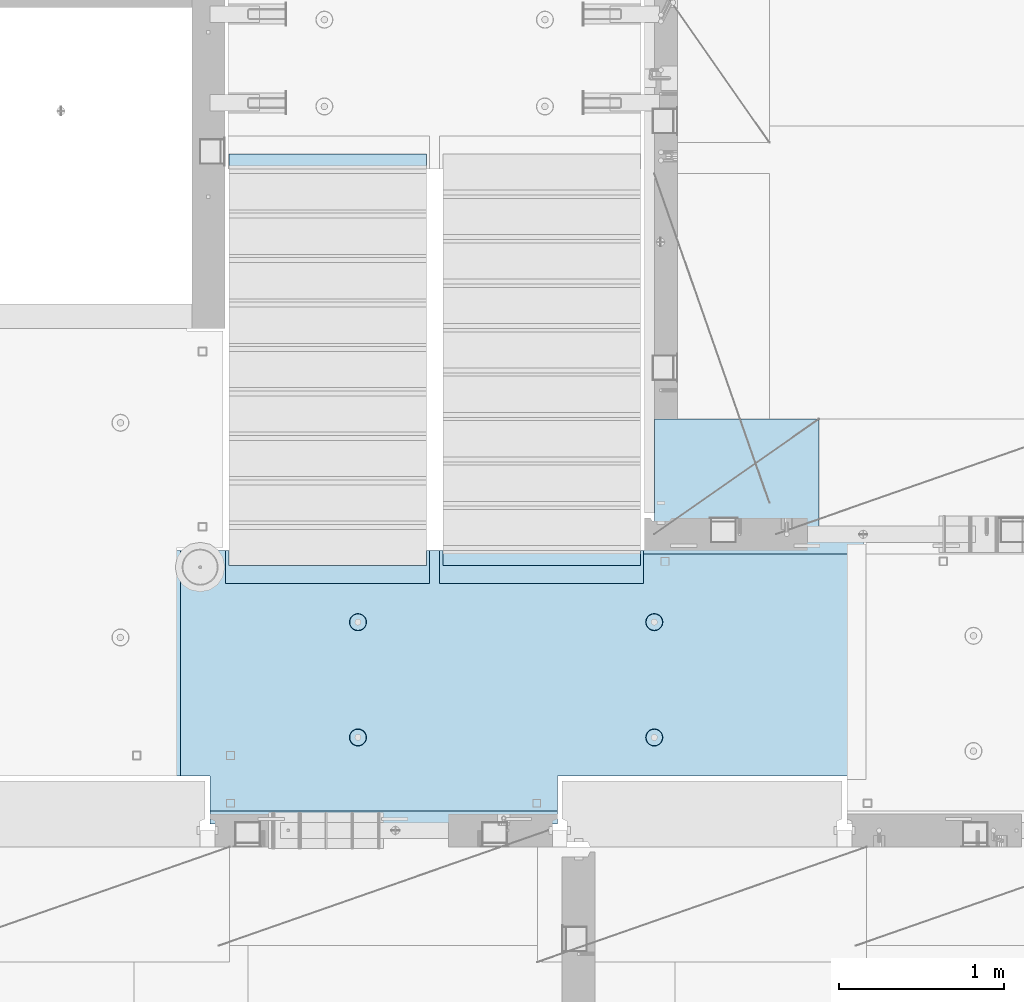
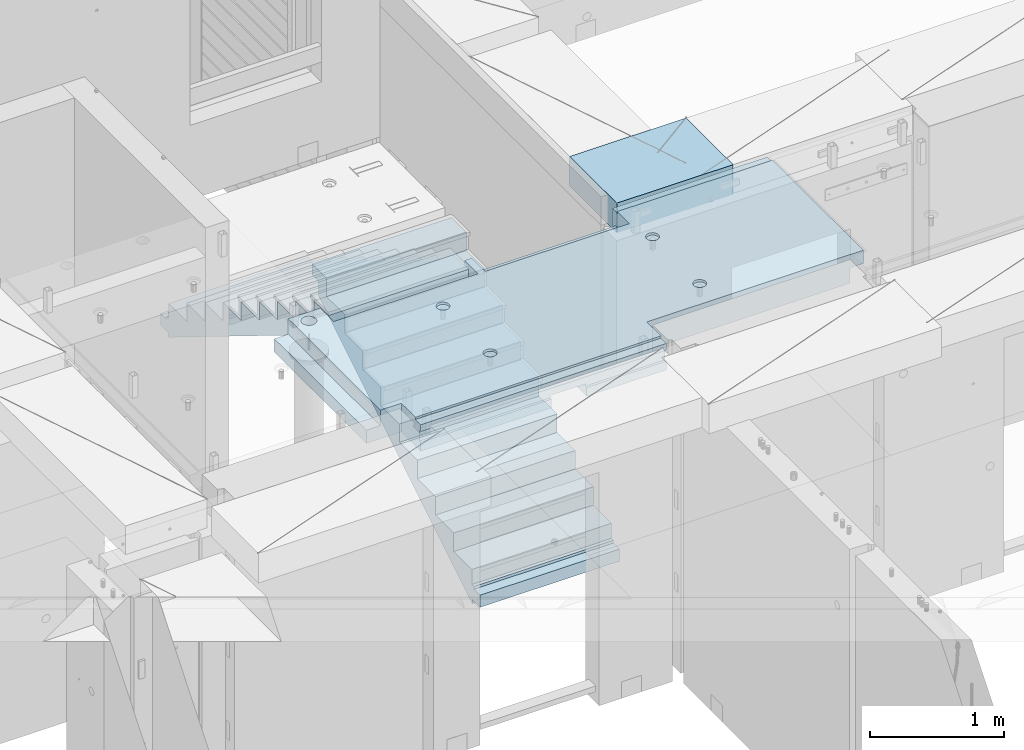
# One storey, part 207 of 349: 3 plates, 1 slab, 4 elements without a shape of their own.
"""IFC2X3 building model written with IfcOpenShell, lengths in millimetres."""

from ifc_helpers import new_model, si_unit, frame, origin_with_axes, place, context, subcontext, project, spatial, faceted_brep, material, type_object, element, aggregate, save


model = new_model("IFC2X3")

# Units and contexts
model_context = context("Model", 3, precision=1e-05, world=origin_with_axes())
body_context = subcontext(model_context, "Body", "Model", "MODEL_VIEW")
ifc_project = project(units=[si_unit("LENGTHUNIT", "METRE", prefix="MILLI"), si_unit("AREAUNIT", "SQUARE_METRE"), si_unit("VOLUMEUNIT", "CUBIC_METRE"), si_unit("MASSUNIT", "GRAM", prefix="KILO"), si_unit("TIMEUNIT", "SECOND"), si_unit("PLANEANGLEUNIT", "RADIAN"), si_unit("SOLIDANGLEUNIT", "STERADIAN"), si_unit("THERMODYNAMICTEMPERATUREUNIT", "DEGREE_CELSIUS"), si_unit("LUMINOUSINTENSITYUNIT", "LUMEN")], contexts=[model_context])

# Site, building, storey
site_placement = place(None, origin_with_axes())
site = spatial("IfcSite", under=ifc_project, at=site_placement, CompositionType="ELEMENT")
building_placement = place(site_placement, origin_with_axes())
building = spatial("IfcBuilding", under=site, at=building_placement, CompositionType="ELEMENT")
storey_placement = place(building_placement, origin_with_axes())
storey = spatial("IfcBuildingStorey", under=building, at=storey_placement, Name="4", CompositionType="ELEMENT", Elevation=0.0)

# Assembly, slab
assembly_1_placement = place(storey_placement, origin_with_axes())
assembly_1 = element("IfcElementAssembly", 1, at=assembly_1_placement, inside=storey, AssemblyPlace="NOTDEFINED", PredefinedType="REINFORCEMENT_UNIT")
ifc_material_1 = material(Name="CONCRETE/C25/30")
slab_type = type_object("IfcSlabType", PredefinedType="NOTDEFINED")
slab_placement = place(assembly_1_placement, frame((23540.0159390845, 15510.0026483125, 93620.0), z_axis=(-0.999999999997437, -2.26400000064461e-06, 0.0), x_axis=(-2.2639999995273e-06, 0.999999999997437, 0.0)))
slab = element("IfcSlab", 2, at=slab_placement, type_object=slab_type, material=ifc_material_1, PredefinedType="FLOOR", context=body_context, shape_type="Brep", body=[
    faceted_brep([(-269.991394356101, 30.0, 2845.00213671412), (-79.9935682977648, 30.0, 2845.00213671301), (-79.9942474988402, 30.0, 2545.001661275), (-269.991475956112, 30.0, 2545.00209142873), (-79.9935682977648, 130.0, 2845.00213671301), (-269.991394356102, 50.0011356208415, 2845.00213671412), (-289.993566176285, 50.0011356208415, 2845.00213671423), (-289.993566176285, 130.0, 2845.00213671423), (-79.9942474988402, 130.0, 2545.001661275), (-289.994243058944, 130.0, 2545.00213671499), (-289.994243058944, 50.0011356208415, 2545.00213671499), (-269.991475956114, 50.0011356208415, 2545.00209142873), (250.667816023648, -110.0, 1223.00869116667), (264.606228919523, -110.0, 1230.11066726268), (275.667816023648, -110.0, 1241.1722543668), (282.76979211966, -110.0, 1255.11066726268), (285.216966304903, -110.0, 1270.56151698143), (282.769792119658, -110.0, 1286.01236670018), (275.667816023648, -110.0, 1299.95077959605), (264.606228919525, -110.0, 1311.01236670018), (250.667816023648, -110.0, 1318.11434279619), (235.216966304901, -110.0, 1320.56151698143), (219.766116586154, -110.0, 1318.11434279619), (205.827703690276, -110.0, 1311.01236670018), (194.766116586154, -110.0, 1299.95077959605), (187.664140490142, -110.0, 1286.01236670018), (185.216966304899, -110.0, 1270.56151698143), (187.664140490144, -110.0, 1255.11066726268), (194.766116586154, -110.0, 1241.1722543668), (205.827703690276, -110.0, 1230.11066726268), (219.766116586154, -110.0, 1223.00869116667), (235.216966304901, -110.0, 1220.56151698143), (251.370127374501, -130.0, 1220.84719908418), (235.216966304901, -130.0, 1218.2887897087), (265.942104492917, -130.0, 1228.27199227546), (277.506491010863, -130.0, 1239.83637879341), (284.931284202146, -130.0, 1254.40835591183), (287.489693577627, -130.0, 1270.56151698143), (284.931284202146, -130.0, 1286.71467805103), (277.506491010861, -130.0, 1301.28665516945), (265.942104492917, -130.0, 1312.85104168739), (251.370127374501, -130.0, 1320.27583487867), (235.216966304901, -130.0, 1322.83424425416), (219.063805235301, -130.0, 1320.27583487867), (204.491828116883, -130.0, 1312.85104168739), (192.927441598938, -130.0, 1301.28665516945), (185.502648407655, -130.0, 1286.71467805103), (182.944239032175, -130.0, 1270.56151698143), (185.502648407655, -130.0, 1254.40835591183), (192.92744159894, -130.0, 1239.83637879341), (204.491828116883, -130.0, 1228.27199227546), (219.063805235301, -130.0, 1220.84719908418), (1370.00988769532, 9.99999999994179, 4270.0029296875), (0.00703133410206647, 9.99999999994179, 4270.00341796875), (0.00594789032584231, 9.99999999994179, 4150.00335886026), (1370.00950450419, 9.99999999994179, 4150.0022190173), (1370.00988769532, 130.0, 4270.0029296875), (0.00703133410206647, 130.0, 4270.00341796875), (-289.995788574217, 50.0011356208415, 1860.01696777343), (-269.99166227209, 50.0011356208415, 1860.01689198933), (-289.995788574217, 130.0, 1860.01696777343), (1410.00403637765, -10.0000000000582, 115.00218916441), (-0.000334584017764428, -10.0000000000582, 115.003668258996), (-0.000334584015945438, 130.0, 115.003668258996), (1430.00436377147, 130.0, 115.002168181909), (1430.00283514406, 50.0011356437899, 115.002168184747), (1410.00403637764, 50.0011356208415, 115.002189163421), (1430.00659179688, 130.0, 1330.01220703125), (1370.00036621094, 130.0, 1330.01281738281), (1370.00036621094, -110.000000000073, 1330.01281738281), (1430.00659179688, -110.000000000073, 1330.01220703125), (1430.00656714066, -110.000000000073, 1.33804860524833e-08), (1350.00656713971, -110.000000000073, -1.09139364212751e-10), (1350.00656713971, -130.0, -9.31322574615479e-10), (0.0, -130.0, -3.63797880709171e-12), (0.0, -10.0, 0.0), (1410.00416932017, -10.0000000000582, 1.69893610291183e-09), (1410.00416932017, -49.9988643791585, 5.89352566748858e-10), (1430.00416932019, -49.9988643791585, 2.83398549072444e-09), (1430.00277003324, 50.0011356208415, 1270.01537795496), (1430.00277003324, -49.9988643791585, 1270.01537795496), (1410.00277003325, 50.0011356208415, 1270.01535591496), (1410.00277003325, -49.9988643791585, 1270.01535591496), (-0.00148380931932479, -130.0, 510.016937255856), (-0.00148380931932479, 130.0, 510.016937255856), (0.00156440050341189, -130.0, 1860.01586914062), (0.00156440050341189, 130.0, 1860.01586914062), (-209.991713751984, -130.000000000058, 1860.01666468411), (-209.996345203012, -130.0, 3970.01713194715), (-209.996345203012, -110.000000000058, 3970.01713194715), (-209.991713751984, -110.000000000058, 1860.01666468411), (-289.991027832028, -110.000000000058, 3970.01733398437), (-289.995788574217, -110.000000000058, 1860.01696777343), (-289.991027832028, -49.9988643791585, 3970.01733398437), (-289.995788574217, -49.9988643791585, 1860.01696777343), (-269.99166227209, -49.9988643791585, 1860.01689198933), (-289.991027832028, 50.0011356208415, 3970.01733398437), (-289.991027832028, 130.0, 3970.01733398437), (-269.991088351981, 50.0011356208415, 3970.01728347186), (-269.991088351981, -49.9988643791585, 3970.01728347186), (0.00432284502676339, -130.0, 3970.0166015625), (0.00432284502676339, 130.0, 3970.0166015625), (0.00594789032584231, -130.0, 4150.00335886026), (1370.00950450419, -130.000000000058, 4150.0022190173), (1370.00860847198, 9.99639270307671, 3875.01157736929), (1170.00318277859, 9.99639270307671, 3875.01203018158), (1170.00037541444, 9.99639270307671, 2635.01019913007), (1370.00459258838, 9.99639270307671, 2635.00974632052), (1370.00860847197, -130.000000000058, 3875.01157736929), (1170.00318277859, -130.000000000029, 3875.01203018158), (1170.00037541444, -130.000000000029, 2635.01019913007), (1370.00459258838, -130.000000000029, 2635.00974632052), (1370.00439827764, -130.000000000029, 2575.01157737549), (1170.00023957859, -130.000000000029, 2575.01203018491), (1170.00023957859, 9.99639270307671, 2575.01203018491), (1370.00439827764, 9.99639270307671, 2575.01157737549), (1169.99743221444, -130.000000000029, 1335.0101991334), (1169.99743221444, 9.99639270307671, 1335.0101991334), (1370.00038239405, 9.99639270307671, 1335.00974632672), (1370.00038239405, -110.000000000073, 1335.00974632672), (1350.00004294686, -110.000000000073, 1335.00979160748), (1350.00004294686, -130.000000000073, 1335.00979160748), (920.332855772751, -110.0, 1318.11282667454), (906.394410719273, -110.0, 1311.01091369173), (895.332773528397, -110.0, 1299.94937667459), (888.230734319324, -110.0, 1286.01099593661), (885.78349017266, -110.0, 1270.56015729882), (888.230594396427, -110.0, 1255.10929649942), (895.332507379233, -110.0, 1241.17085144594), (906.394044396377, -110.0, 1230.10921425507), (920.332425134358, -110.0, 1223.00717504599), (935.783263772144, -110.0, 1220.55993089933), (951.234124571543, -110.0, 1223.0070351231), (965.172569625021, -110.0, 1230.10894810591), (976.234206815898, -110.0, 1241.17048512305), (983.33624602497, -110.0, 1255.10886586103), (985.783490171634, -110.0, 1270.55970449882), (983.336385947867, -110.0, 1286.01056529821), (976.234472965061, -110.0, 1299.94901035169), (965.172935947918, -110.0, 1311.01064754257), (951.234555209936, -110.0, 1318.11268675164), (935.783716572147, -110.0, 1320.5599308983), (951.936426135147, -130.0, 1220.84553986057), (935.783253481237, -130.0, 1218.28720362663), (966.508436872882, -130.0, 1228.27026706986), (978.072875754253, -130.0, 1239.83460122415), (985.497734927369, -130.0, 1254.40654472295), (988.05621744434, -130.0, 1270.55969420791), (985.497881210395, -130.0, 1286.71286686182), (978.073154001104, -130.0, 1301.28487759955), (966.508819846818, -130.0, 1312.84931648092), (951.936876348012, -130.0, 1320.27417565404), (935.783726863054, -130.0, 1322.83265817101), (919.630554209147, -130.0, 1320.27432193707), (905.058543471412, -130.0, 1312.84959472777), (893.494104590041, -130.0, 1301.28526057349), (886.069245416922, -130.0, 1286.71331707469), (883.510762899954, -130.0, 1270.56016758973), (886.069099133892, -130.0, 1254.40699493582), (893.49382634319, -130.0, 1239.83498419809), (905.058160497476, -130.0, 1228.27054531671), (919.630103996282, -130.0, 1220.84568614359), (920.336931380272, -110.0, 3118.29282666992), (906.398486326791, -110.0, 3111.19091368712), (895.336849135918, -110.0, 3100.12937666997), (888.234809926846, -110.0, 3086.19099593199), (885.787565780181, -110.0, 3070.7401572942), (888.234670003949, -110.0, 3055.28929649481), (895.336582986754, -110.0, 3041.35085144133), (906.398120003898, -110.0, 3030.28921425045), (920.33650074188, -110.0, 3023.18717504138), (935.787339379665, -110.0, 3020.73993089472), (951.238200179065, -110.0, 3023.18703511849), (965.176645232543, -110.0, 3030.28894810129), (976.238282423419, -110.0, 3041.35048511844), (983.340321632491, -110.0, 3055.28886585642), (985.787565779156, -110.0, 3070.7397044942), (983.340461555388, -110.0, 3086.1905652936), (976.238548572583, -110.0, 3100.12901034708), (965.177011555439, -110.0, 3111.19064753796), (951.238630817454, -110.0, 3118.29268674703), (935.787792179664, -110.0, 3120.73993089369), (951.940501742669, -130.000000000015, 3021.02553985595), (935.787329088758, -130.000000000015, 3018.46720362201), (966.512512480404, -130.000000000015, 3028.45026706525), (978.076951361778, -130.000000000015, 3040.01460121954), (985.50181053489, -130.000000000015, 3054.58654471834), (988.060293051862, -130.000000000015, 3070.73969420329), (985.501956817916, -130.000000000015, 3086.89286685721), (978.077229608625, -130.000000000015, 3101.46487759494), (966.51289545434, -130.000000000015, 3113.02931647631), (951.940951955534, -130.000000000015, 3120.45417564943), (935.787802470575, -130.000000000015, 3123.01265816639), (919.634629816665, -130.000000000015, 3120.45432193246), (905.062619078933, -130.000000000015, 3113.02959472316), (893.498180197559, -130.000000000015, 3101.46526056888), (886.07332102444, -130.000000000015, 3086.89331707007), (883.514838507475, -130.000000000015, 3070.74016758511), (886.073174741414, -130.000000000015, 3054.5869949312), (893.497901950712, -130.000000000015, 3040.01498419347), (905.062236104997, -130.000000000015, 3028.4505453121), (919.634179603803, -130.000000000015, 3021.02568613898), (250.671891631169, -110.0, 3023.18869116206), (264.610304527045, -110.0, 3030.29066725807), (275.671891631167, -110.0, 3041.35225436219), (282.773867727179, -110.0, 3055.29066725806), (285.221041912424, -110.0, 3070.74151697681), (282.773867727179, -110.0, 3086.19236669556), (275.671891631169, -110.0, 3100.13077959144), (264.610304527047, -110.0, 3111.19236669556), (250.671891631169, -110.0, 3118.29434279157), (235.221041912422, -110.0, 3120.74151697681), (219.770192193675, -110.0, 3118.29434279157), (205.831779297798, -110.0, 3111.19236669556), (194.770192193675, -110.0, 3100.13077959144), (187.668216097663, -110.0, 3086.19236669556), (185.22104191242, -110.0, 3070.74151697681), (187.668216097663, -110.0, 3055.29066725806), (194.770192193673, -110.0, 3041.35225436219), (205.831779297798, -110.0, 3030.29066725807), (219.770192193673, -110.0, 3023.18869116206), (235.221041912422, -110.0, 3020.74151697681), (251.374202982022, -130.0, 3021.02719907957), (235.221041912422, -130.0, 3018.46878970409), (265.946180100438, -130.0, 3028.45199227085), (277.510566618384, -130.0, 3040.0163787888), (284.935359809668, -130.0, 3054.58835590722), (287.493769185148, -130.0, 3070.74151697681), (284.935359809668, -130.0, 3086.89467804641), (277.510566618383, -130.0, 3101.46665516483), (265.946180100438, -130.0, 3113.03104168278), (251.374202982022, -130.0, 3120.45583487406), (235.22104191242, -130.0, 3123.01424424954), (219.067880842822, -130.0, 3120.45583487406), (204.495903724404, -130.0, 3113.03104168278), (192.93151720646, -130.0, 3101.46665516483), (185.506724015177, -130.0, 3086.89467804641), (182.948314639694, -130.0, 3070.74151697681), (185.506724015177, -130.0, 3054.58835590722), (192.93151720646, -130.0, 3040.0163787888), (204.495903724404, -130.0, 3028.45199227085), (219.06788084282, -130.0, 3021.02719907957), (1234.74413944682, -130.000000000029, 3981.4733287671), (1221.47026497402, -130.000000000029, 3994.74726334413), (1212.94793152671, -130.000000000029, 4011.47337811379), (1210.0113644813, -130.000000000029, 4030.01440442472), (1212.94801548044, -130.000000000029, 4048.55541743869), (1221.47042466352, -130.000000000029, 4065.28149361904), (1234.74435924055, -130.000000000029, 4078.55536809184), (1251.47047401021, -130.000000000029, 4087.07770153915), (1270.01150032114, -130.000000000029, 4090.01426858456), (1288.55251333511, -130.000000000029, 4087.07761758541), (1305.27858951547, -130.000000000029, 4078.55520840234), (1318.55246398826, -130.000000000029, 4065.28127382531), (1327.07479743557, -130.000000000029, 4048.55515905565), (1330.01136448099, -130.000000000029, 4030.01413274472), (1327.07471348184, -130.000000000029, 4011.47311973075), (1318.55230429877, -130.000000000029, 3994.74704355039), (1305.27836972173, -130.000000000029, 3981.4731690776), (1288.55225495208, -130.000000000029, 3972.95083563029), (1270.01122864114, -130.000000000029, 3970.01426858487), (1251.47021562717, -130.000000000029, 3972.95091958403), (1305.27836972173, 130.0, 3981.4731690776), (1288.55225495208, 130.0, 3972.95083563029), (1318.55230429877, 130.0, 3994.74704355039), (1327.07471348184, 130.0, 4011.47311973075), (1330.01136448099, 130.0, 4030.01413274472), (1327.07479743557, 130.0, 4048.55515905565), (1318.55246398826, 130.0, 4065.28127382531), (1305.27858951547, 130.0, 4078.55520840234), (1288.55251333511, 130.0, 4087.07761758541), (1270.01150032114, 130.0, 4090.01426858456), (1251.47047401021, 130.0, 4087.07770153915), (1234.74435924055, 130.0, 4078.55536809184), (1221.47042466352, 130.0, 4065.28149361904), (1212.94801548044, 130.0, 4048.55541743869), (1210.0113644813, 130.0, 4030.01440442472), (1212.94793152671, 130.0, 4011.47337811379), (1221.47026497402, 130.0, 3994.74726334413), (1234.74413944682, 130.0, 3981.4733287671), (1251.47021562717, 130.0, 3972.95091958403), (1270.01122864114, 130.0, 3970.01426858487)], [[[0, 1, 2, 3]], [[4, 1, 0, 5, 6, 7]], [[8, 2, 1, 4]], [[9, 10, 11, 3, 2, 8]], [[12, 13, 14, 15, 16, 17, 18, 19, 20, 21, 22, 23, 24, 25, 26, 27, 28, 29, 30, 31]], [[32, 12, 31, 33]], [[34, 13, 12, 32]], [[35, 14, 13, 34]], [[36, 15, 14, 35]], [[37, 16, 15, 36]], [[38, 17, 16, 37]], [[39, 18, 17, 38]], [[40, 19, 18, 39]], [[41, 20, 19, 40]], [[42, 21, 20, 41]], [[43, 22, 21, 42]], [[44, 23, 22, 43]], [[45, 24, 23, 44]], [[46, 25, 24, 45]], [[47, 26, 25, 46]], [[48, 27, 26, 47]], [[49, 28, 27, 48]], [[50, 29, 28, 49]], [[51, 30, 29, 50]], [[33, 31, 30, 51]], [[52, 53, 54, 55]], [[56, 57, 53, 52]], [[58, 59, 11, 10]], [[60, 58, 10, 9]], [[61, 62, 63, 64, 65, 66]], [[67, 68, 69, 70]], [[71, 72, 73, 74, 75, 76, 77, 78]], [[79, 65, 64, 67, 70, 71, 78, 80]], [[65, 79, 81, 66]], [[80, 82, 81, 79]], [[78, 77, 82, 80]], [[76, 61, 66, 81, 82, 77]], [[75, 62, 61, 76]], [[74, 83, 84, 63, 62, 75]], [[83, 85, 86, 84]], [[87, 88, 89, 90]], [[90, 89, 91, 92]], [[92, 91, 93, 94]], [[58, 60, 86, 85, 87, 90, 92, 94, 95, 59]], [[96, 97, 7, 6]], [[98, 96, 6, 5]], [[59, 95, 99, 98, 5, 0, 3, 11]], [[94, 93, 99, 95]], [[91, 89, 88, 100, 101, 97, 96, 98, 99, 93]], [[53, 57, 101, 100, 102, 54]], [[103, 55, 54, 102]], [[104, 105, 106, 107]], [[108, 109, 105, 104]], [[110, 106, 105, 109]], [[111, 107, 106, 110]], [[112, 113, 114, 115]], [[116, 117, 114, 113]], [[115, 114, 117, 118]], [[69, 68, 56, 52, 55, 103, 108, 104, 107, 111, 112, 115, 118, 119]], [[72, 71, 70, 69, 119, 120]], [[73, 72, 120, 121]], [[119, 118, 117, 116, 121, 120]], [[122, 123, 124, 125, 126, 127, 128, 129, 130, 131, 132, 133, 134, 135, 136, 137, 138, 139, 140, 141]], [[142, 132, 131, 143]], [[144, 133, 132, 142]], [[145, 134, 133, 144]], [[146, 135, 134, 145]], [[147, 136, 135, 146]], [[148, 137, 136, 147]], [[149, 138, 137, 148]], [[150, 139, 138, 149]], [[151, 140, 139, 150]], [[152, 141, 140, 151]], [[153, 122, 141, 152]], [[154, 123, 122, 153]], [[155, 124, 123, 154]], [[156, 125, 124, 155]], [[157, 126, 125, 156]], [[158, 127, 126, 157]], [[159, 128, 127, 158]], [[160, 129, 128, 159]], [[161, 130, 129, 160]], [[143, 131, 130, 161]], [[162, 163, 164, 165, 166, 167, 168, 169, 170, 171, 172, 173, 174, 175, 176, 177, 178, 179, 180, 181]], [[182, 172, 171, 183]], [[184, 173, 172, 182]], [[185, 174, 173, 184]], [[186, 175, 174, 185]], [[187, 176, 175, 186]], [[188, 177, 176, 187]], [[189, 178, 177, 188]], [[190, 179, 178, 189]], [[191, 180, 179, 190]], [[192, 181, 180, 191]], [[193, 162, 181, 192]], [[194, 163, 162, 193]], [[195, 164, 163, 194]], [[196, 165, 164, 195]], [[197, 166, 165, 196]], [[198, 167, 166, 197]], [[199, 168, 167, 198]], [[200, 169, 168, 199]], [[201, 170, 169, 200]], [[183, 171, 170, 201]], [[202, 203, 204, 205, 206, 207, 208, 209, 210, 211, 212, 213, 214, 215, 216, 217, 218, 219, 220, 221]], [[222, 202, 221, 223]], [[224, 203, 202, 222]], [[225, 204, 203, 224]], [[226, 205, 204, 225]], [[227, 206, 205, 226]], [[228, 207, 206, 227]], [[229, 208, 207, 228]], [[230, 209, 208, 229]], [[231, 210, 209, 230]], [[232, 211, 210, 231]], [[233, 212, 211, 232]], [[234, 213, 212, 233]], [[235, 214, 213, 234]], [[236, 215, 214, 235]], [[237, 216, 215, 236]], [[238, 217, 216, 237]], [[239, 218, 217, 238]], [[240, 219, 218, 239]], [[241, 220, 219, 240]], [[223, 221, 220, 241]], [[113, 112, 111, 110, 109, 108, 103, 102, 100, 88, 87, 85, 83, 74, 73, 121, 116], [240, 239, 238, 237, 236, 235, 234, 233, 232, 231, 230, 229, 228, 227, 226, 225, 224, 222, 223, 241], [200, 199, 198, 197, 196, 195, 194, 193, 192, 191, 190, 189, 188, 187, 186, 185, 184, 182, 183, 201], [160, 159, 158, 157, 156, 155, 154, 153, 152, 151, 150, 149, 148, 147, 146, 145, 144, 142, 143, 161], [50, 49, 48, 47, 46, 45, 44, 43, 42, 41, 40, 39, 38, 37, 36, 35, 34, 32, 33, 51], [242, 243, 244, 245, 246, 247, 248, 249, 250, 251, 252, 253, 254, 255, 256, 257, 258, 259, 260, 261]], [[258, 262, 263, 259]], [[257, 264, 262, 258]], [[256, 265, 264, 257]], [[255, 266, 265, 256]], [[254, 267, 266, 255]], [[253, 268, 267, 254]], [[252, 269, 268, 253]], [[251, 270, 269, 252]], [[250, 271, 270, 251]], [[249, 272, 271, 250]], [[248, 273, 272, 249]], [[247, 274, 273, 248]], [[246, 275, 274, 247]], [[245, 276, 275, 246]], [[244, 277, 276, 245]], [[243, 278, 277, 244]], [[242, 279, 278, 243]], [[261, 280, 279, 242]], [[260, 281, 280, 261]], [[259, 263, 281, 260]], [[7, 97, 101, 57, 56, 68, 67, 64, 63, 84, 86, 60, 9, 8, 4], [262, 264, 265, 266, 267, 268, 269, 270, 271, 272, 273, 274, 275, 276, 277, 278, 279, 280, 281, 263]]]),
])
aggregate(assembly_1, [slab])

# Assembly, plate
assembly_2_placement = place(storey_placement, origin_with_axes())
assembly_2 = element("IfcElementAssembly", 3, at=assembly_2_placement, inside=storey, Name="E9", AssemblyPlace="NOTDEFINED", PredefinedType="NOTDEFINED")
ifc_material_2 = material(Name="Undefined/C32/40")
plate_type_1 = type_object("IfcPlateType", PredefinedType="NOTDEFINED")
plate_1_placement = place(assembly_2_placement, frame((20285.0002457424, 19199.9998138874, 92260.0), z_axis=(0.0, -1.0, 0.0), x_axis=(0.0, 0.0, -1.0)))
plate_1 = element("IfcPlate", 4, at=plate_1_placement, type_object=plate_type_1, material=ifc_material_2, Name="E9", context=body_context, shape_type="Brep", body=[
    faceted_brep([(0.0, -600.0, 0.0), (0.0, -600.0, 30.0), (0.0, 600.0, 30.0), (0.0, 600.0, 0.0), (-136.699996948242, -600.0, 30.0), (-136.699996948242, 600.0, 30.0), (-136.699996948242, -600.0, 300.0), (-136.699996948242, 600.0, 300.0), (-303.399993896484, -600.0, 300.0), (-303.399993896484, 600.0, 300.0), (-303.399993896484, -600.0, 570.0), (-303.399993896484, 600.0, 570.0), (-470.100006103516, -600.0, 570.0), (-470.100006103516, 600.0, 570.0), (-470.100006103516, -600.0, 840.0), (-470.100006103516, 600.0, 840.0), (-636.799987792969, -600.0, 840.0), (-636.799987792969, 600.0, 840.0), (-636.799987792969, -600.0, 1110.0), (-636.799987792969, 600.0, 1110.0), (-803.5, -600.0, 1110.0), (-803.5, 600.0, 1110.0), (-803.5, -600.0, 1380.0), (-803.5, 600.0, 1380.0), (-970.200012207031, -600.0, 1380.0), (-970.200012207031, 600.0, 1380.0), (-970.200012207031, -600.0, 1650.0), (-970.200012207031, 600.0, 1650.0), (-1136.90002441406, -600.0, 1650.0), (-1136.90002441406, 600.0, 1650.0), (-1136.90002441406, -600.0, 1920.0), (-1136.90002441406, 600.0, 1920.0), (-1303.59997558594, -600.0, 1920.0), (-1303.59997558594, 600.0, 1920.0), (-1303.59997558594, -600.0, 2190.0), (-1303.59997558594, 600.0, 2190.0), (-1470.30004882813, -600.0, 2190.0), (-1470.30004882813, 600.0, 2190.0), (-1470.30004882813, -600.0, 2410.0), (-1470.30004882813, 600.0, 2410.0), (-1370.30004882813, -600.0, 2410.0), (-1370.30004882813, 600.0, 2410.0), (-1370.30004882813, -600.0, 2310.0), (-1370.30004882813, 600.0, 2310.0), (-1236.65991210938, -600.0, 2310.0), (-1236.65991210938, 600.0, 2310.0), (170.0, -600.0, 31.6665592193604), (170.0, 600.0, 31.6665592193604), (170.0, -600.0, 20.0), (170.0, 600.0, 20.0), (135.0, -600.0, 20.0), (135.0, 600.0, 20.0), (135.0, -600.0, -90.0), (135.0, 600.0, -90.0), (25.0, -600.0, -90.0), (25.0, 600.0, -90.0), (25.0, -600.0, 0.0), (25.0, 600.0, 0.0)], [[[0, 1, 2, 3]], [[1, 4, 5, 2]], [[4, 6, 7, 5]], [[6, 8, 9, 7]], [[8, 10, 11, 9]], [[10, 12, 13, 11]], [[12, 14, 15, 13]], [[14, 16, 17, 15]], [[16, 18, 19, 17]], [[18, 20, 21, 19]], [[20, 22, 23, 21]], [[22, 24, 25, 23]], [[24, 26, 27, 25]], [[26, 28, 29, 27]], [[28, 30, 31, 29]], [[30, 32, 33, 31]], [[32, 34, 35, 33]], [[34, 36, 37, 35]], [[36, 38, 39, 37]], [[38, 40, 41, 39]], [[40, 42, 43, 41]], [[42, 44, 45, 43]], [[44, 46, 47, 45]], [[46, 48, 49, 47]], [[48, 50, 51, 49]], [[50, 52, 53, 51]], [[52, 54, 55, 53]], [[54, 56, 57, 55]], [[56, 0, 3, 57]], [[5, 7, 9, 11, 13, 15, 17, 19, 21, 23, 25, 27, 29, 31, 33, 35, 37, 39, 41, 43, 45, 47, 49, 51, 53, 55, 57, 3, 2]], [[56, 54, 52, 50, 48, 46, 44, 42, 40, 38, 36, 34, 32, 30, 28, 26, 24, 22, 20, 18, 16, 14, 12, 10, 8, 6, 4, 1, 0]]]),
])
aggregate(assembly_2, [plate_1])

assembly_3_placement = place(storey_placement, origin_with_axes())
assembly_3 = element("IfcElementAssembly", 5, at=assembly_3_placement, inside=storey, Name="E9", AssemblyPlace="NOTDEFINED", PredefinedType="NOTDEFINED")
plate_2_placement = place(assembly_3_placement, frame((21585.002175553, 16880.001025346, 90759.7036072969), z_axis=(0.0, 1.0, 0.0), x_axis=(0.0, 0.0, -1.0)))
plate_2 = element("IfcPlate", 6, at=plate_2_placement, type_object=plate_type_1, material=ifc_material_2, Name="E9", context=body_context, shape_type="Brep", body=[
    faceted_brep([(0.0, -600.0, 0.0), (0.0, -600.0, 30.0), (0.0, 600.0, 30.0), (0.0, 600.0, 0.0), (-136.699996948242, -600.0, 30.0), (-136.699996948242, 600.0, 30.0), (-136.699996948242, -600.0, 300.0), (-136.699996948242, 600.0, 300.0), (-303.399993896484, -600.0, 300.0), (-303.399993896484, 600.0, 300.0), (-303.399993896484, -600.0, 570.0), (-303.399993896484, 600.0, 570.0), (-470.100006103516, -600.0, 570.0), (-470.100006103516, 600.0, 570.0), (-470.100006103516, -600.0, 840.0), (-470.100006103516, 600.0, 840.0), (-636.799987792969, -600.0, 840.0), (-636.799987792969, 600.0, 840.0), (-636.799987792969, -600.0, 1110.0), (-636.799987792969, 600.0, 1110.0), (-803.5, -600.0, 1110.0), (-803.5, 600.0, 1110.0), (-803.5, -600.0, 1380.0), (-803.5, 600.0, 1380.0), (-970.200012207031, -600.0, 1380.0), (-970.200012207031, 600.0, 1380.0), (-970.200012207031, -600.0, 1650.0), (-970.200012207031, 600.0, 1650.0), (-1136.90002441406, -600.0, 1650.0), (-1136.90002441406, 600.0, 1650.0), (-1136.90002441406, -600.0, 1920.0), (-1136.90002441406, 600.0, 1920.0), (-1303.59997558594, -600.0, 1920.0), (-1303.59997558594, 600.0, 1920.0), (-1303.59997558594, -600.0, 2190.0), (-1303.59997558594, 600.0, 2190.0), (-1470.30004882813, -600.0, 2190.0), (-1470.30004882813, 600.0, 2190.0), (-1470.30004882813, -600.0, 2410.0), (-1470.30004882813, 600.0, 2410.0), (-1370.30004882813, -600.0, 2410.0), (-1370.30004882813, 600.0, 2410.0), (-1370.30004882813, -600.0, 2310.0), (-1370.30004882813, 600.0, 2310.0), (-1236.65991210938, -600.0, 2310.0), (-1236.65991210938, 600.0, 2310.0), (170.0, -600.0, 31.6665592193604), (170.0, 600.0, 31.6665592193604), (170.0, -600.0, 20.0), (170.0, 600.0, 20.0), (135.0, -600.0, 20.0), (135.0, 600.0, 20.0), (135.0, -600.0, -90.0), (135.0, 600.0, -90.0), (25.0, -600.0, -90.0), (25.0, 600.0, -90.0), (25.0, -600.0, 0.0), (25.0, 600.0, 0.0)], [[[0, 1, 2, 3]], [[1, 4, 5, 2]], [[4, 6, 7, 5]], [[6, 8, 9, 7]], [[8, 10, 11, 9]], [[10, 12, 13, 11]], [[12, 14, 15, 13]], [[14, 16, 17, 15]], [[16, 18, 19, 17]], [[18, 20, 21, 19]], [[20, 22, 23, 21]], [[22, 24, 25, 23]], [[24, 26, 27, 25]], [[26, 28, 29, 27]], [[28, 30, 31, 29]], [[30, 32, 33, 31]], [[32, 34, 35, 33]], [[34, 36, 37, 35]], [[36, 38, 39, 37]], [[38, 40, 41, 39]], [[40, 42, 43, 41]], [[42, 44, 45, 43]], [[44, 46, 47, 45]], [[46, 48, 49, 47]], [[48, 50, 51, 49]], [[50, 52, 53, 51]], [[52, 54, 55, 53]], [[54, 56, 57, 55]], [[56, 0, 3, 57]], [[5, 7, 9, 11, 13, 15, 17, 19, 21, 23, 25, 27, 29, 31, 33, 35, 37, 39, 41, 43, 45, 47, 49, 51, 53, 55, 57, 3, 2]], [[56, 54, 52, 50, 48, 46, 44, 42, 40, 38, 36, 34, 32, 30, 28, 26, 24, 22, 20, 18, 16, 14, 12, 10, 8, 6, 4, 1, 0]]]),
])
aggregate(assembly_3, [plate_2])

assembly_4_placement = place(storey_placement, origin_with_axes())
assembly_4 = element("IfcElementAssembly", 7, at=assembly_4_placement, inside=storey, Name="Steel Assembly", AssemblyPlace="NOTDEFINED", PredefinedType="NOTDEFINED")
ifc_material_3 = material()
plate_type_2 = type_object("IfcPlateType", PredefinedType="NOTDEFINED")
plate_3_placement = place(assembly_4_placement, frame((22270.0, 16979.9999999293, 93595.3), z_axis=(0.0, 1.0, 0.0), x_axis=(1.0, 0.0, 0.0)))
plate_3 = element("IfcPlate", 8, at=plate_3_placement, type_object=plate_type_2, material=ifc_material_3, Name="RE1_1/2", context=body_context, shape_type="Brep", body=[
    faceted_brep([(1.81898940354586e-12, -135.0, 1.81898940354586e-12), (0.0, -135.0, 699.999999999996), (0.0, 135.0, 699.999999999996), (1.81898940354586e-12, 135.0, 1.81898940354586e-12), (999.99951171875, -135.0, 700.0), (999.99951171875, 135.0, 700.0), (1000.0, -135.0, 0.0), (1000.0, 135.0, 0.0)], [[[0, 1, 2, 3]], [[1, 4, 5, 2]], [[4, 6, 7, 5]], [[6, 0, 3, 7]], [[5, 7, 3, 2]], [[6, 4, 1, 0]]]),
])
aggregate(assembly_4, [plate_3])

save(model, "model.ifc")
